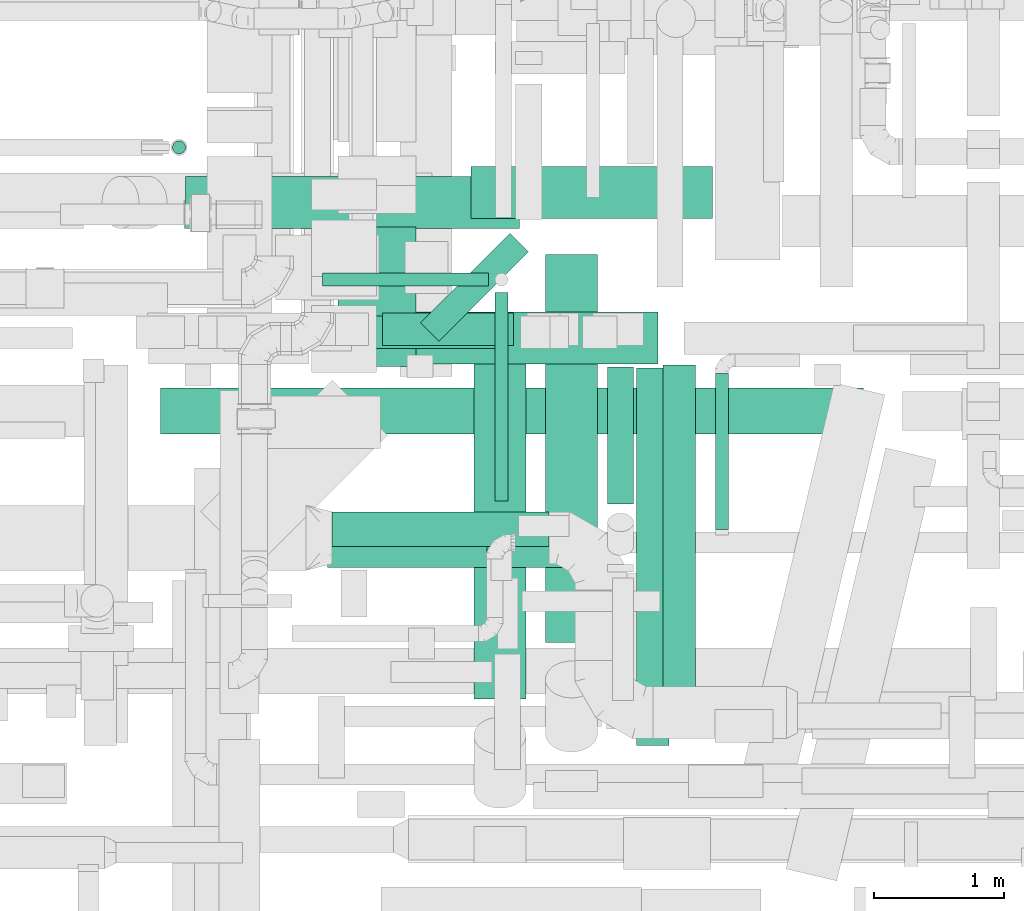
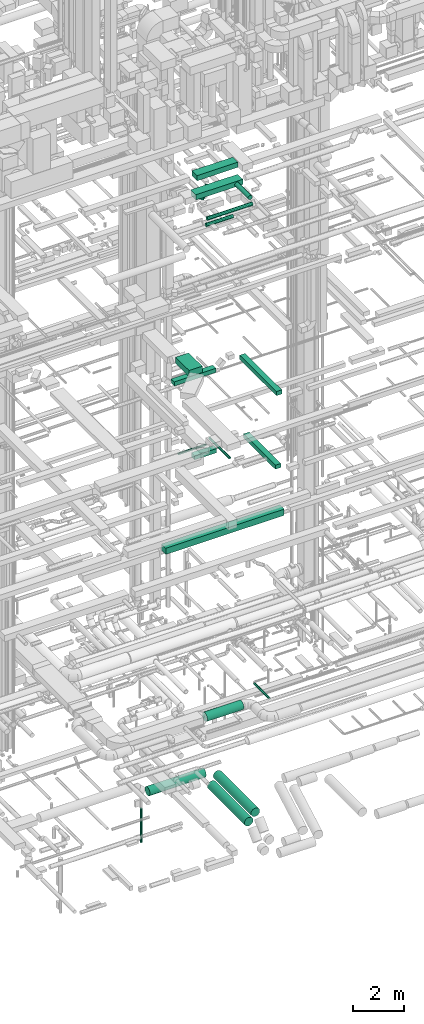
# One storey, part 39 of 337: 20 flow segments.
"""IFC2X3 building model written with IfcOpenShell, lengths in millimetres."""

from ifc_helpers import new_model, entity, si_unit, converted_unit, derived_unit, direction, frame, origin, origin_2d_with_axis, place, context, subcontext, project, spatial, rectangle, circle, extrude, type_object, element, save


model = new_model("IFC2X3")

# Units and contexts
model_context = context("Model", 3, precision=0.01, world=origin(), true_north=direction((6.12303176911189e-17, 1.0)))
body_context = subcontext(model_context, "Body", "Model", "MODEL_VIEW")
ifc_project = project(units=[si_unit("LENGTHUNIT", "METRE", prefix="MILLI"), si_unit("AREAUNIT", "SQUARE_METRE"), si_unit("VOLUMEUNIT", "CUBIC_METRE"), converted_unit("PLANEANGLEUNIT", "DEGREE", entity("IfcRatioMeasure", 0.0174532925199433), si_unit("PLANEANGLEUNIT", "RADIAN"), dimensions=[0, 0, 0, 0, 0, 0, 0]), si_unit("MASSUNIT", "GRAM", prefix="KILO"), derived_unit("MASSDENSITYUNIT", [(si_unit("MASSUNIT", "GRAM", prefix="KILO"), 1), (si_unit("LENGTHUNIT", "METRE"), -3)]), derived_unit("MOMENTOFINERTIAUNIT", [(si_unit("LENGTHUNIT", "METRE"), 4)]), si_unit("TIMEUNIT", "SECOND"), si_unit("FREQUENCYUNIT", "HERTZ"), si_unit("THERMODYNAMICTEMPERATUREUNIT", "DEGREE_CELSIUS"), derived_unit("THERMALTRANSMITTANCEUNIT", [(si_unit("MASSUNIT", "GRAM", prefix="KILO"), 1), (si_unit("THERMODYNAMICTEMPERATUREUNIT", "KELVIN"), -1), (si_unit("TIMEUNIT", "SECOND"), -3)]), derived_unit("VOLUMETRICFLOWRATEUNIT", [(si_unit("LENGTHUNIT", "METRE"), 3), (si_unit("TIMEUNIT", "SECOND"), -1)]), derived_unit("MASSFLOWRATEUNIT", [(si_unit("MASSUNIT", "GRAM", prefix="KILO"), 1), (si_unit("TIMEUNIT", "SECOND"), -1)]), derived_unit("ROTATIONALFREQUENCYUNIT", [(si_unit("TIMEUNIT", "SECOND"), -1)]), si_unit("ELECTRICCURRENTUNIT", "AMPERE"), si_unit("ELECTRICVOLTAGEUNIT", "VOLT"), si_unit("POWERUNIT", "WATT"), si_unit("FORCEUNIT", "NEWTON", prefix="KILO"), si_unit("ILLUMINANCEUNIT", "LUX"), si_unit("LUMINOUSFLUXUNIT", "LUMEN"), si_unit("LUMINOUSINTENSITYUNIT", "CANDELA"), derived_unit("USERDEFINED", [(si_unit("MASSUNIT", "GRAM", prefix="KILO"), -1), (si_unit("LENGTHUNIT", "METRE"), -2), (si_unit("TIMEUNIT", "SECOND"), 3), (si_unit("LUMINOUSFLUXUNIT", "LUMEN"), 1)]), derived_unit("LINEARVELOCITYUNIT", [(si_unit("LENGTHUNIT", "METRE"), 1), (si_unit("TIMEUNIT", "SECOND"), -1)]), si_unit("PRESSUREUNIT", "PASCAL"), derived_unit("USERDEFINED", [(si_unit("LENGTHUNIT", "METRE"), -2), (si_unit("MASSUNIT", "GRAM", prefix="KILO"), 1), (si_unit("TIMEUNIT", "SECOND"), -2)]), derived_unit("LINEARFORCEUNIT", [(si_unit("MASSUNIT", "GRAM", prefix="KILO"), 1), (si_unit("LENGTHUNIT", "METRE"), 1), (si_unit("TIMEUNIT", "SECOND"), -2), (si_unit("LENGTHUNIT", "METRE"), -1)]), derived_unit("PLANARFORCEUNIT", [(si_unit("MASSUNIT", "GRAM", prefix="KILO"), 1), (si_unit("LENGTHUNIT", "METRE"), 1), (si_unit("TIMEUNIT", "SECOND"), -2), (si_unit("LENGTHUNIT", "METRE"), -2)])], contexts=[model_context])

# Site, building, storey
site_placement = place(None, origin())
site = spatial("IfcSite", under=ifc_project, at=site_placement, CompositionType="ELEMENT")
building_placement = place(site_placement, origin())
building = spatial("IfcBuilding", under=site, at=building_placement, CompositionType="ELEMENT")
storey_placement = place(building_placement, origin())
storey = spatial("IfcBuildingStorey", under=building, at=storey_placement, CompositionType="ELEMENT", Elevation=0.0)

# Flow segments
duct_segment_type_1 = type_object("IfcDuctSegmentType", PredefinedType="NOTDEFINED")
flow_segment_1_placement = place(storey_placement, frame((48857.3, 4945.54, 11250.0)))
element("IfcFlowSegment", 1, at=flow_segment_1_placement, inside=storey, type_object=duct_segment_type_1, context=body_context, shape_type="SweptSolid", body=[
    extrude(rectangle(XDim=5400.00000000001, YDim=349.999999999999, at=origin_2d_with_axis()), frame((2700.0, 175.0, 0.0)), (0.0, 0.0, 1.0), 300.000000000001),
])
flow_segment_2_placement = place(storey_placement, frame((52515.22, 2552.06, 19075.0)))
element("IfcFlowSegment", 2, at=flow_segment_2_placement, inside=storey, type_object=duct_segment_type_1, context=body_context, shape_type="SweptSolid", body=[
    extrude(rectangle(XDim=2898.74999999984, YDim=250.000000000004, at=origin_2d_with_axis()), frame((125.0, 1449.37, 0.0), z_axis=(0.0, 0.0, 1.0), x_axis=(0.0, -1.0, 0.0)), (0.0, 0.0, 1.0), 200.000000000002),
])
flow_segment_3_placement = place(storey_placement, frame((49623.18, 5600.81, 18700.59)))
element("IfcFlowSegment", 3, at=flow_segment_3_placement, inside=storey, type_object=duct_segment_type_1, context=body_context, shape_type="SweptSolid", body=[
    extrude(rectangle(XDim=1892.89321881349, YDim=249.999999999999, at=origin_2d_with_axis()), frame((946.45, 125.0, 0.0)), (0.0, 0.0, 1.0), 200.000000000002),
])
flow_segment_4_placement = place(storey_placement, frame((50220.03, 5463.6, 19025.0)))
element("IfcFlowSegment", 4, at=flow_segment_4_placement, inside=storey, type_object=duct_segment_type_1, context=body_context, shape_type="SweptSolid", body=[
    extrude(rectangle(XDim=1069.73593128807, YDim=600.000000000002, at=origin_2d_with_axis()), frame((300.0, 534.87, 0.0), z_axis=(0.0, 0.0, 1.0), x_axis=(0.0, -1.0, 0.0)), (0.0, 0.0, 1.0), 300.000000000001),
])
flow_segment_5_placement = place(storey_placement, frame((50562.28, 5625.44, 14800.0)))
element("IfcFlowSegment", 5, at=flow_segment_5_placement, inside=storey, type_object=duct_segment_type_1, context=body_context, shape_type="SweptSolid", body=[
    extrude(rectangle(XDim=1005.45321881342, YDim=250.000000000001, at=origin_2d_with_axis()), frame((502.73, 125.0, 0.0)), (0.0, 0.0, 1.0), 200.000000000002),
])
flow_segment_6_placement = place(storey_placement, frame((52716.01, 2975.44, 15200.0)))
element("IfcFlowSegment", 6, at=flow_segment_6_placement, inside=storey, type_object=duct_segment_type_1, context=body_context, shape_type="SweptSolid", body=[
    extrude(rectangle(XDim=2500.0, YDim=250.000000000004, at=origin_2d_with_axis()), frame((125.0, 1250.0, 0.0), z_axis=(0.0, 0.0, 1.0), x_axis=(0.0, -1.0, 0.0)), (0.0, 0.0, 1.0), 200.000000000002),
])
flow_segment_7_placement = place(storey_placement, frame((51240.82, 6599.99, 27425.0)))
element("IfcFlowSegment", 7, at=flow_segment_7_placement, inside=storey, type_object=duct_segment_type_1, context=body_context, shape_type="SweptSolid", body=[
    extrude(rectangle(XDim=1855.00000000017, YDim=400.0, at=origin_2d_with_axis()), frame((927.5, 200.0, 0.0)), (0.0, 0.0, 1.0), 250.000000000004),
])
flow_segment_8_placement = place(storey_placement, frame((50854.18, 5656.2, 27150.0)))
element("IfcFlowSegment", 8, at=flow_segment_8_placement, inside=storey, type_object=duct_segment_type_1, context=body_context, shape_type="SweptSolid", body=[
    extrude(rectangle(XDim=972.89321881346, YDim=199.999999999996, at=origin_2d_with_axis()), frame((414.68, 414.68, 0.0), z_axis=(0.0, 0.0, 1.0), x_axis=(-0.707106781186553, -0.707106781186542, 0.0)), (0.0, 0.0, 1.0), 100.000000000003),
])
flow_segment_9_placement = place(storey_placement, frame((50536.44, 5480.28, 27425.0)))
element("IfcFlowSegment", 9, at=flow_segment_9_placement, inside=storey, type_object=duct_segment_type_1, context=body_context, shape_type="SweptSolid", body=[
    extrude(rectangle(XDim=2140.94331110318, YDim=400.0, at=origin_2d_with_axis()), frame((1070.47, 200.0, 0.0)), (0.0, 0.0, 1.0), 250.000000000004),
])
duct_segment_type_2 = type_object("IfcDuctSegmentType", PredefinedType="NOTDEFINED")
flow_segment_10_placement = place(storey_placement, frame((49048.06, 6521.49, -1501.6)))
element("IfcFlowSegment", 10, at=flow_segment_10_placement, inside=storey, type_object=duct_segment_type_2, context=body_context, shape_type="SweptSolid", body=[
    extrude(circle(Radius=200.0, at=origin_2d_with_axis()), frame((0.0, 201.6, 201.6), z_axis=(1.0, 0.0, 0.0), x_axis=(0.0, 1.0, 0.0)), (0.0, 0.0, 1.0), 2566.03464522663),
])
flow_segment_11_placement = place(storey_placement, frame((51812.5, 3340.82, -1501.6)))
element("IfcFlowSegment", 11, at=flow_segment_11_placement, inside=storey, type_object=duct_segment_type_2, context=body_context, shape_type="SweptSolid", body=[
    extrude(circle(Radius=200.0, at=origin_2d_with_axis()), frame((201.6, 0.0, 201.6), z_axis=(0.0, 1.0, 0.0), x_axis=(-1.0, 0.0, 0.0)), (0.0, 0.0, 1.0), 2982.26908799999),
])
flow_segment_12_placement = place(storey_placement, frame((51262.56, 2909.23, -1501.6)))
element("IfcFlowSegment", 12, at=flow_segment_12_placement, inside=storey, type_object=duct_segment_type_2, context=body_context, shape_type="SweptSolid", body=[
    extrude(circle(Radius=200.0, at=origin_2d_with_axis()), frame((201.6, 0.0, 201.6), z_axis=(0.0, 1.0, 0.0), x_axis=(-1.0, 0.0, 0.0)), (0.0, 0.0, 1.0), 2914.31457505077),
])
flow_segment_13_placement = place(storey_placement, frame((48947.78, 7094.64, -3995.0)))
element("IfcFlowSegment", 13, at=flow_segment_13_placement, inside=storey, type_object=duct_segment_type_2, context=body_context, shape_type="SweptSolid", body=[
    extrude(circle(Radius=50.0, at=origin_2d_with_axis()), frame((51.6, 51.6, 0.0), z_axis=(0.0, 0.0, 1.0), x_axis=(-1.0, 0.0, 0.0)), (0.0, 0.0, 1.0), 1634.99999999999),
])
flow_segment_14_placement = place(storey_placement, frame((50175.84, 3944.65, 3248.4)))
element("IfcFlowSegment", 14, at=flow_segment_14_placement, inside=storey, type_object=duct_segment_type_2, context=body_context, shape_type="SweptSolid", body=[
    extrude(circle(Radius=200.0, at=origin_2d_with_axis()), frame((0.0, 201.6, 201.6), z_axis=(1.0, 0.0, 0.0), x_axis=(0.0, -1.0, 0.0)), (0.0, 0.0, 1.0), 1665.00000000002),
])
flow_segment_15_placement = place(storey_placement, frame((50099.97, 6078.27, 14898.4)))
element("IfcFlowSegment", 15, at=flow_segment_15_placement, inside=storey, type_object=duct_segment_type_2, context=body_context, shape_type="SweptSolid", body=[
    extrude(circle(Radius=50.0, at=origin_2d_with_axis()), frame((0.0, 51.6, 51.6), z_axis=(1.0, 0.0, 0.0), x_axis=(0.0, -1.0, 0.0)), (0.0, 0.0, 1.0), 1276.03988687724),
])
flow_segment_16_placement = place(storey_placement, frame((51424.41, 4428.15, 15248.4)))
element("IfcFlowSegment", 16, at=flow_segment_16_placement, inside=storey, type_object=duct_segment_type_2, context=body_context, shape_type="SweptSolid", body=[
    extrude(circle(Radius=50.0, at=origin_2d_with_axis()), frame((51.6, 0.0, 51.6), z_axis=(0.0, 1.0, 0.0), x_axis=(-1.0, 0.0, 0.0)), (0.0, 0.0, 1.0), 1601.71604445706),
])
flow_segment_17_placement = place(storey_placement, frame((50181.52, 3916.51, 27468.4)))
element("IfcFlowSegment", 17, at=flow_segment_17_placement, inside=storey, type_object=duct_segment_type_2, context=body_context, shape_type="SweptSolid", body=[
    extrude(circle(Radius=80.0, at=origin_2d_with_axis()), frame((0.0, 81.6, 81.6), z_axis=(1.0, 0.0, 0.0), x_axis=(0.0, 1.0, 0.0)), (0.0, 0.0, 1.0), 2068.12499999997),
])
flow_segment_18_placement = place(storey_placement, frame((50138.69, 3916.51, 27178.4)))
element("IfcFlowSegment", 18, at=flow_segment_18_placement, inside=storey, type_object=duct_segment_type_2, context=body_context, shape_type="SweptSolid", body=[
    extrude(circle(Radius=80.0, at=origin_2d_with_axis()), frame((0.0, 81.6, 81.6), z_axis=(1.0, 0.0, 0.0), x_axis=(0.0, 1.0, 0.0)), (0.0, 0.0, 1.0), 1225.00000000001),
])
flow_segment_19_placement = place(storey_placement, frame((52289.77, 4406.25, 27448.4)))
element("IfcFlowSegment", 19, at=flow_segment_19_placement, inside=storey, type_object=duct_segment_type_2, context=body_context, shape_type="SweptSolid", body=[
    extrude(circle(Radius=100.0, at=origin_2d_with_axis()), frame((101.6, 0.0, 101.6), z_axis=(0.0, 1.0, 0.0), x_axis=(-1.0, 0.0, 0.0)), (0.0, 0.0, 1.0), 1054.0300999793),
])
flow_segment_20_placement = place(storey_placement, frame((53117.27, 4210.29, 3198.4)))
element("IfcFlowSegment", 20, at=flow_segment_20_placement, inside=storey, type_object=duct_segment_type_2, context=body_context, shape_type="SweptSolid", body=[
    extrude(circle(Radius=50.0, at=origin_2d_with_axis()), frame((51.6, 0.0, 51.6), z_axis=(0.0, 1.0, 0.0), x_axis=(-1.0, 0.0, 0.0)), (0.0, 0.0, 1.0), 1200.00000000001),
])

save(model, "model.ifc")
